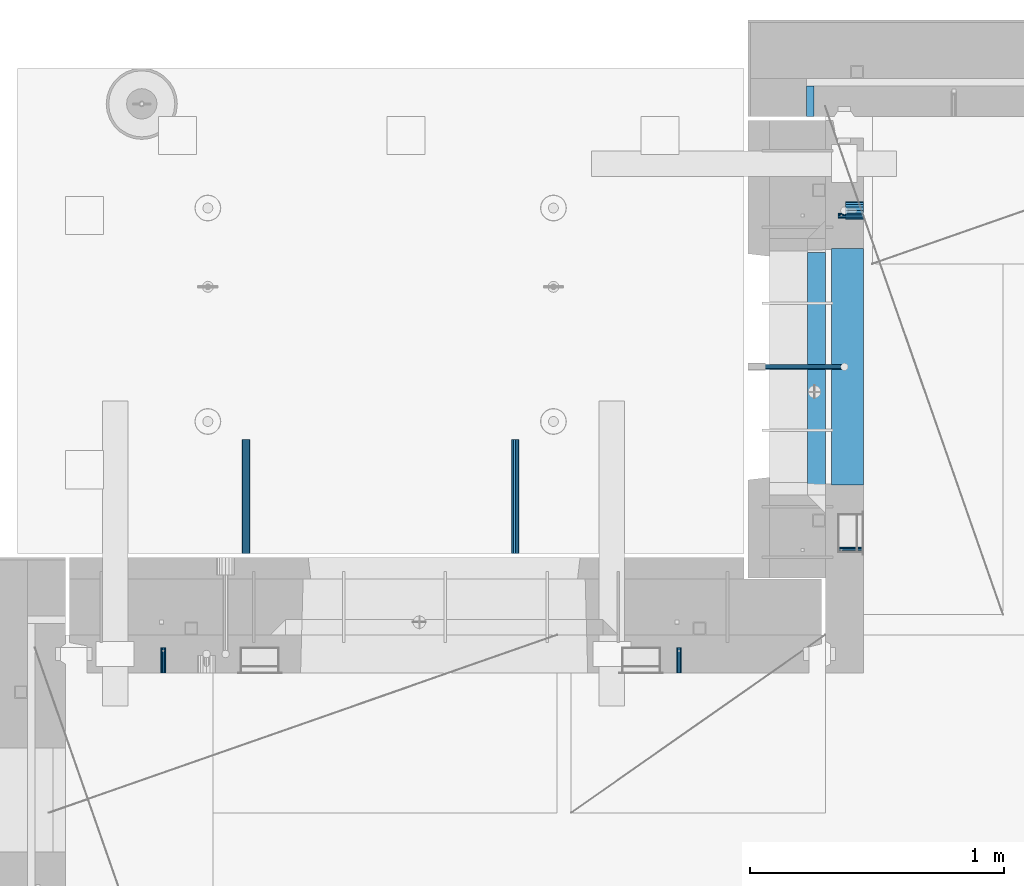
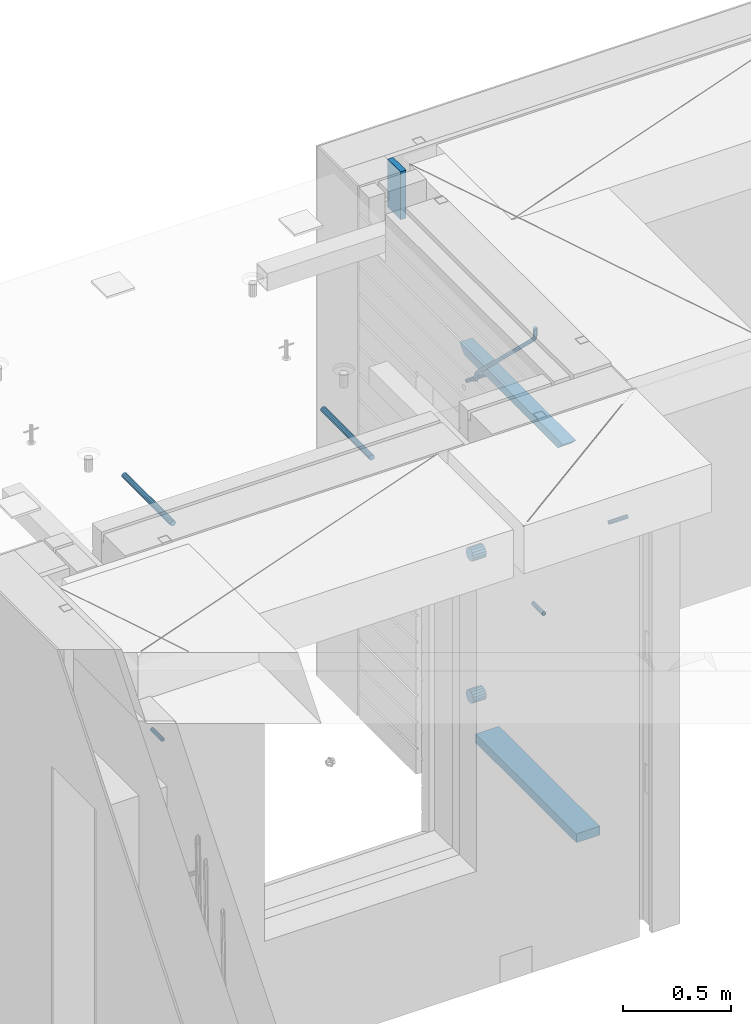
# One storey, part 132 of 309: 12 beams, 10 elements without a shape of their own.
"""IFC2X3 building model written with IfcOpenShell, lengths in millimetres."""

from ifc_helpers import new_model, si_unit, frame, origin_with_axes, place, context, subcontext, project, spatial, faceted_brep, material, type_object, element, aggregate, save


model = new_model("IFC2X3")

# Units and contexts
model_context = context("Model", 3, precision=1e-05, world=origin_with_axes())
body_context = subcontext(model_context, "Body", "Model", "MODEL_VIEW")
ifc_project = project(units=[si_unit("LENGTHUNIT", "METRE", prefix="MILLI"), si_unit("AREAUNIT", "SQUARE_METRE"), si_unit("VOLUMEUNIT", "CUBIC_METRE"), si_unit("MASSUNIT", "GRAM", prefix="KILO"), si_unit("TIMEUNIT", "SECOND"), si_unit("PLANEANGLEUNIT", "RADIAN"), si_unit("SOLIDANGLEUNIT", "STERADIAN"), si_unit("THERMODYNAMICTEMPERATUREUNIT", "DEGREE_CELSIUS"), si_unit("LUMINOUSINTENSITYUNIT", "LUMEN")], contexts=[model_context])

# Site, building, storey
site_placement = place(None, origin_with_axes())
site = spatial("IfcSite", under=ifc_project, at=site_placement, CompositionType="ELEMENT")
building_placement = place(site_placement, origin_with_axes())
building = spatial("IfcBuilding", under=site, at=building_placement, CompositionType="ELEMENT")
storey_placement = place(building_placement, origin_with_axes())
storey = spatial("IfcBuildingStorey", under=building, at=storey_placement, Name="7", CompositionType="ELEMENT", Elevation=0.0)

# Assembly, beam
assembly_1_placement = place(storey_placement, origin_with_axes())
assembly_1 = element("IfcElementAssembly", 1, at=assembly_1_placement, inside=storey, AssemblyPlace="NOTDEFINED", PredefinedType="REINFORCEMENT_UNIT")
ifc_material_1 = material(Name="CONCRETE/C25/30")
beam_type_1 = type_object("IfcBeamType", PredefinedType="NOTDEFINED")
beam_1_placement = place(assembly_1_placement, frame((10955.0, 22139.9998901814, 102080.0), z_axis=(0.0, 0.0, -1.0), x_axis=(0.0, -1.0, 0.0)))
beam_1 = element("IfcBeam", 2, at=beam_1_placement, type_object=beam_type_1, material=ifc_material_1, Name="SK", context=body_context, shape_type="Brep", body=[
    faceted_brep([(100.641025641038, 35.0, 20.6410256410309), (55.0, 35.0, -25.0), (55.0, -35.0, -25.0), (98.8461538461561, -35.0, 18.8461538461561), (966.153464684117, -35.0, 18.8461538461561), (964.358592889246, 35.0, 20.6410256410309), (1009.99961853027, 35.0, -25.0), (1009.99961853027, -35.0, -25.0)], [[[0, 1, 2, 3]], [[0, 3, 4, 5]], [[1, 0, 5, 6]], [[2, 1, 6, 7]], [[3, 2, 7, 4]], [[4, 7, 6, 5]]]),
])

# Assemblies, beams
assembly_2_placement = place(storey_placement, origin_with_axes())
assembly_2 = element("IfcElementAssembly", 3, at=assembly_2_placement, inside=storey, AssemblyPlace="NOTDEFINED", PredefinedType="REINFORCEMENT_UNIT")
assembly_3_placement = place(assembly_2_placement, origin_with_axes())
assembly_3 = element("IfcElementAssembly", 4, at=assembly_3_placement, Name="Steel Assembly", AssemblyPlace="NOTDEFINED", PredefinedType="RIGID_FRAME")
ifc_material_2 = material(Name="STEEL/Steel_Undefined")
beam_type_2 = type_object("IfcBeamType", PredefinedType="NOTDEFINED")
beam_2_placement = place(assembly_3_placement, frame((8384.50481277243, 20430.0, 101754.84), z_axis=(-1.0, 3.00000001838171e-08, 0.0), x_axis=(0.0, 1.0, 0.0)))
beam_2 = element("IfcBeam", 5, at=beam_2_placement, type_object=beam_type_2, material=ifc_material_2, context=body_context, shape_type="Brep", body=[
    faceted_brep([(0.0, -8.49999999999272, -1.45519152283669e-11), (0.0, -7.36121593215648, 4.24999999998545), (100.000000000262, -7.36121593215648, 4.24999999998545), (100.000000000262, -8.49999999999272, -1.45519152283669e-11), (0.0, -4.24999999998545, 7.36121593216376), (100.000000000262, -4.24999999998545, 7.36121593216376), (0.0, 1.45519152283669e-11, 8.49999999998545), (100.000000000262, 1.45519152283669e-11, 8.49999999998545), (0.0, 4.25000000001455, 7.36121593216376), (100.000000000262, 4.25000000001455, 7.36121593216376), (0.0, 7.36121593217104, 4.24999999998545), (100.000000000262, 7.36121593217104, 4.24999999998545), (0.0, 8.50000000000728, 0.0), (100.000000000262, 8.50000000000728, 0.0), (0.0, 7.36121593217104, -4.25000000001455), (100.000000000262, 7.36121593217104, -4.25000000001455), (0.0, 4.25000000000728, -7.36121593219286), (100.000000000262, 4.25000000000728, -7.36121593219286), (0.0, 7.27595761418343e-12, -8.5), (100.000000000262, 7.27595761418343e-12, -8.5), (0.0, -4.24999999999272, -7.36121593217831), (100.000000000262, -4.24999999999272, -7.36121593217831), (0.0, -7.36121593215648, -4.25), (100.000000000262, -7.36121593215648, -4.25), (0.0, -10.4999999999927, -1.45519152283669e-11), (0.0, -9.09326673972828, -5.25000000001455), (100.000000000262, -9.09326673972828, -5.25000000001455), (100.000000000262, -10.4999999999927, -1.45519152283669e-11), (0.0, -5.24999999998545, -9.09326673974283), (100.000000000262, -5.24999999998545, -9.09326673974283), (0.0, 7.27595761418343e-12, -10.5), (100.000000000262, 7.27595761418343e-12, -10.5), (0.0, 5.25000000001455, -9.09326673975738), (100.000000000262, 5.25000000001455, -9.09326673975738), (0.0, 9.09326673975011, -5.25000000001455), (100.000000000262, 9.09326673975011, -5.25000000001455), (0.0, 10.5000000000073, -1.45519152283669e-11), (100.000000000262, 10.5000000000073, -1.45519152283669e-11), (0.0, 9.09326673975011, 5.25), (100.000000000262, 9.09326673975011, 5.25), (0.0, 5.25000000000728, 9.09326673972828), (100.000000000262, 5.25000000000728, 9.09326673972828), (0.0, 1.45519152283669e-11, 10.4999999999854), (100.000000000262, 1.45519152283669e-11, 10.4999999999854), (0.0, -5.24999999999272, 9.09326673972828), (100.000000000262, -5.24999999999272, 9.09326673972828), (0.0, -9.09326673972828, 5.24999999998545), (100.000000000262, -9.09326673972828, 5.24999999998545)], [[[0, 1, 2, 3]], [[1, 4, 5, 2]], [[4, 6, 7, 5]], [[6, 8, 9, 7]], [[8, 10, 11, 9]], [[10, 12, 13, 11]], [[12, 14, 15, 13]], [[14, 16, 17, 15]], [[16, 18, 19, 17]], [[18, 20, 21, 19]], [[20, 22, 23, 21]], [[22, 0, 3, 23]], [[24, 25, 26, 27]], [[25, 28, 29, 26]], [[28, 30, 31, 29]], [[30, 32, 33, 31]], [[32, 34, 35, 33]], [[34, 36, 37, 35]], [[36, 38, 39, 37]], [[38, 40, 41, 39]], [[40, 42, 43, 41]], [[42, 44, 45, 43]], [[44, 46, 47, 45]], [[46, 24, 27, 47]], [[29, 31, 33, 35, 37, 39, 41, 43, 45, 47, 27, 26], [5, 7, 9, 11, 13, 15, 17, 19, 21, 23, 3, 2]], [[46, 44, 42, 40, 38, 36, 34, 32, 30, 28, 25, 24], [22, 20, 18, 16, 14, 12, 10, 8, 6, 4, 1, 0]]]),
])
aggregate(assembly_3, [beam_2])
assembly_4_placement = place(assembly_2_placement, origin_with_axes())
assembly_4 = element("IfcElementAssembly", 6, at=assembly_4_placement, Name="Steel Assembly", AssemblyPlace="NOTDEFINED", PredefinedType="RIGID_FRAME")
aggregate(assembly_2, [assembly_3, assembly_4])
beam_3_placement = place(assembly_4_placement, frame((10414.5048127724, 20430.0, 101754.84), z_axis=(-1.0, 3.00000001838171e-08, 0.0), x_axis=(0.0, 1.0, 0.0)))
beam_3 = element("IfcBeam", 7, at=beam_3_placement, type_object=beam_type_2, material=ifc_material_2, context=body_context, shape_type="Brep", body=[
    faceted_brep([(0.0, -8.49999999999272, -1.45519152283669e-11), (0.0, -7.36121593215648, 4.24999999998545), (100.000000000262, -7.36121593215648, 4.24999999998545), (100.000000000262, -8.49999999999272, -1.45519152283669e-11), (0.0, -4.24999999998545, 7.36121593216376), (100.000000000262, -4.24999999998545, 7.36121593216376), (0.0, 1.45519152283669e-11, 8.49999999998545), (100.000000000262, 1.45519152283669e-11, 8.49999999998545), (0.0, 4.25000000001455, 7.36121593216376), (100.000000000262, 4.25000000001455, 7.36121593216376), (0.0, 7.36121593217104, 4.24999999998545), (100.000000000262, 7.36121593217104, 4.24999999998545), (0.0, 8.50000000000728, 0.0), (100.000000000262, 8.50000000000728, 0.0), (0.0, 7.36121593217104, -4.25000000001455), (100.000000000262, 7.36121593217104, -4.25000000001455), (0.0, 4.25000000000728, -7.36121593219286), (100.000000000262, 4.25000000000728, -7.36121593219286), (0.0, 7.27595761418343e-12, -8.5), (100.000000000262, 7.27595761418343e-12, -8.5), (0.0, -4.24999999999272, -7.36121593217831), (100.000000000262, -4.24999999999272, -7.36121593217831), (0.0, -7.36121593215648, -4.25), (100.000000000262, -7.36121593215648, -4.25), (0.0, -10.4999999999927, -1.45519152283669e-11), (0.0, -9.09326673972828, -5.25000000001455), (100.000000000262, -9.09326673972828, -5.25000000001455), (100.000000000262, -10.4999999999927, -1.45519152283669e-11), (0.0, -5.24999999998545, -9.09326673974283), (100.000000000262, -5.24999999998545, -9.09326673974283), (0.0, 7.27595761418343e-12, -10.5), (100.000000000262, 7.27595761418343e-12, -10.5), (0.0, 5.25000000001455, -9.09326673975738), (100.000000000262, 5.25000000001455, -9.09326673975738), (0.0, 9.09326673975011, -5.25000000001455), (100.000000000262, 9.09326673975011, -5.25000000001455), (0.0, 10.5000000000073, -1.45519152283669e-11), (100.000000000262, 10.5000000000073, -1.45519152283669e-11), (0.0, 9.09326673975011, 5.25), (100.000000000262, 9.09326673975011, 5.25), (0.0, 5.25000000000728, 9.09326673972828), (100.000000000262, 5.25000000000728, 9.09326673972828), (0.0, 1.45519152283669e-11, 10.4999999999854), (100.000000000262, 1.45519152283669e-11, 10.4999999999854), (0.0, -5.24999999999272, 9.09326673972828), (100.000000000262, -5.24999999999272, 9.09326673972828), (0.0, -9.09326673972828, 5.24999999998545), (100.000000000262, -9.09326673972828, 5.24999999998545)], [[[0, 1, 2, 3]], [[1, 4, 5, 2]], [[4, 6, 7, 5]], [[6, 8, 9, 7]], [[8, 10, 11, 9]], [[10, 12, 13, 11]], [[12, 14, 15, 13]], [[14, 16, 17, 15]], [[16, 18, 19, 17]], [[18, 20, 21, 19]], [[20, 22, 23, 21]], [[22, 0, 3, 23]], [[24, 25, 26, 27]], [[25, 28, 29, 26]], [[28, 30, 31, 29]], [[30, 32, 33, 31]], [[32, 34, 35, 33]], [[34, 36, 37, 35]], [[36, 38, 39, 37]], [[38, 40, 41, 39]], [[40, 42, 43, 41]], [[42, 44, 45, 43]], [[44, 46, 47, 45]], [[46, 24, 27, 47]], [[29, 31, 33, 35, 37, 39, 41, 43, 45, 47, 27, 26], [5, 7, 9, 11, 13, 15, 17, 19, 21, 23, 3, 2]], [[46, 44, 42, 40, 38, 36, 34, 32, 30, 28, 25, 24], [22, 20, 18, 16, 14, 12, 10, 8, 6, 4, 1, 0]]]),
])
aggregate(assembly_4, [beam_3])

# Assembly, beam
assembly_5_placement = place(assembly_1_placement, origin_with_axes())
assembly_5 = element("IfcElementAssembly", 8, at=assembly_5_placement, Name="Steel Assembly", AssemblyPlace="NOTDEFINED", PredefinedType="RIGID_FRAME")
beam_4_placement = place(assembly_5_placement, frame((11140.0, 22230.0002037383, 101755.0), z_axis=(0.0, 1.0, 0.0), x_axis=(-1.0, 3.00000001838171e-08, 0.0)))
beam_4 = element("IfcBeam", 9, at=beam_4_placement, type_object=beam_type_2, material=ifc_material_2, Name="M16", context=body_context, shape_type="Brep", body=[
    faceted_brep([(0.0, -8.49999999999272, -1.45519152283669e-11), (0.0, -7.36121593215648, 4.24999999998545), (100.000000000262, -7.36121593215648, 4.24999999998545), (100.000000000262, -8.49999999999272, -1.45519152283669e-11), (0.0, -4.24999999998545, 7.36121593216376), (100.000000000262, -4.24999999998545, 7.36121593216376), (0.0, 1.45519152283669e-11, 8.49999999998545), (100.000000000262, 1.45519152283669e-11, 8.49999999998545), (0.0, 4.25000000001455, 7.36121593216376), (100.000000000262, 4.25000000001455, 7.36121593216376), (0.0, 7.36121593217104, 4.24999999998545), (100.000000000262, 7.36121593217104, 4.24999999998545), (0.0, 8.50000000000728, 0.0), (100.000000000262, 8.50000000000728, 0.0), (0.0, 7.36121593217104, -4.25000000001455), (100.000000000262, 7.36121593217104, -4.25000000001455), (0.0, 4.25000000000728, -7.36121593219286), (100.000000000262, 4.25000000000728, -7.36121593219286), (0.0, 7.27595761418343e-12, -8.5), (100.000000000262, 7.27595761418343e-12, -8.5), (0.0, -4.24999999999272, -7.36121593217831), (100.000000000262, -4.24999999999272, -7.36121593217831), (0.0, -7.36121593215648, -4.25), (100.000000000262, -7.36121593215648, -4.25), (0.0, -10.4999999999927, -1.45519152283669e-11), (0.0, -9.09326673972828, -5.25000000001455), (100.000000000262, -9.09326673972828, -5.25000000001455), (100.000000000262, -10.4999999999927, -1.45519152283669e-11), (0.0, -5.24999999998545, -9.09326673974283), (100.000000000262, -5.24999999998545, -9.09326673974283), (0.0, 7.27595761418343e-12, -10.5), (100.000000000262, 7.27595761418343e-12, -10.5), (0.0, 5.25000000001455, -9.09326673975738), (100.000000000262, 5.25000000001455, -9.09326673975738), (0.0, 9.09326673975011, -5.25000000001455), (100.000000000262, 9.09326673975011, -5.25000000001455), (0.0, 10.5000000000073, -1.45519152283669e-11), (100.000000000262, 10.5000000000073, -1.45519152283669e-11), (0.0, 9.09326673975011, 5.25), (100.000000000262, 9.09326673975011, 5.25), (0.0, 5.25000000000728, 9.09326673972828), (100.000000000262, 5.25000000000728, 9.09326673972828), (0.0, 1.45519152283669e-11, 10.4999999999854), (100.000000000262, 1.45519152283669e-11, 10.4999999999854), (0.0, -5.24999999999272, 9.09326673972828), (100.000000000262, -5.24999999999272, 9.09326673972828), (0.0, -9.09326673972828, 5.24999999998545), (100.000000000262, -9.09326673972828, 5.24999999998545)], [[[0, 1, 2, 3]], [[1, 4, 5, 2]], [[4, 6, 7, 5]], [[6, 8, 9, 7]], [[8, 10, 11, 9]], [[10, 12, 13, 11]], [[12, 14, 15, 13]], [[14, 16, 17, 15]], [[16, 18, 19, 17]], [[18, 20, 21, 19]], [[20, 22, 23, 21]], [[22, 0, 3, 23]], [[24, 25, 26, 27]], [[25, 28, 29, 26]], [[28, 30, 31, 29]], [[30, 32, 33, 31]], [[32, 34, 35, 33]], [[34, 36, 37, 35]], [[36, 38, 39, 37]], [[38, 40, 41, 39]], [[40, 42, 43, 41]], [[42, 44, 45, 43]], [[44, 46, 47, 45]], [[46, 24, 27, 47]], [[29, 31, 33, 35, 37, 39, 41, 43, 45, 47, 27, 26], [5, 7, 9, 11, 13, 15, 17, 19, 21, 23, 3, 2]], [[46, 44, 42, 40, 38, 36, 34, 32, 30, 28, 25, 24], [22, 20, 18, 16, 14, 12, 10, 8, 6, 4, 1, 0]]]),
])
aggregate(assembly_5, [beam_4])

assembly_6_placement = place(assembly_1_placement, origin_with_axes())
assembly_6 = element("IfcElementAssembly", 10, at=assembly_6_placement, Name="Steel Assembly", AssemblyPlace="NOTDEFINED", PredefinedType="RIGID_FRAME")
beam_5_placement = place(assembly_6_placement, frame((11140.0, 20914.9954408996, 101755.0), z_axis=(0.0, -1.0, 0.0), x_axis=(-1.0, 3.00000001838171e-08, 0.0)))
beam_5 = element("IfcBeam", 11, at=beam_5_placement, type_object=beam_type_2, material=ifc_material_2, Name="M16", context=body_context, shape_type="Brep", body=[
    faceted_brep([(0.0, -8.49999999999272, -1.45519152283669e-11), (0.0, -7.36121593215648, 4.24999999998545), (100.000000000262, -7.36121593215648, 4.24999999998545), (100.000000000262, -8.49999999999272, -1.45519152283669e-11), (0.0, -4.24999999998545, 7.36121593216376), (100.000000000262, -4.24999999998545, 7.36121593216376), (0.0, 1.45519152283669e-11, 8.49999999998545), (100.000000000262, 1.45519152283669e-11, 8.49999999998545), (0.0, 4.25000000001455, 7.36121593216376), (100.000000000262, 4.25000000001455, 7.36121593216376), (0.0, 7.36121593217104, 4.24999999998545), (100.000000000262, 7.36121593217104, 4.24999999998545), (0.0, 8.50000000000728, 0.0), (100.000000000262, 8.50000000000728, 0.0), (0.0, 7.36121593217104, -4.25000000001455), (100.000000000262, 7.36121593217104, -4.25000000001455), (0.0, 4.25000000000728, -7.36121593219286), (100.000000000262, 4.25000000000728, -7.36121593219286), (0.0, 7.27595761418343e-12, -8.5), (100.000000000262, 7.27595761418343e-12, -8.5), (0.0, -4.24999999999272, -7.36121593217831), (100.000000000262, -4.24999999999272, -7.36121593217831), (0.0, -7.36121593215648, -4.25), (100.000000000262, -7.36121593215648, -4.25), (0.0, -10.4999999999927, -1.45519152283669e-11), (0.0, -9.09326673972828, -5.25000000001455), (100.000000000262, -9.09326673972828, -5.25000000001455), (100.000000000262, -10.4999999999927, -1.45519152283669e-11), (0.0, -5.24999999998545, -9.09326673974283), (100.000000000262, -5.24999999998545, -9.09326673974283), (0.0, 7.27595761418343e-12, -10.5), (100.000000000262, 7.27595761418343e-12, -10.5), (0.0, 5.25000000001455, -9.09326673975738), (100.000000000262, 5.25000000001455, -9.09326673975738), (0.0, 9.09326673975011, -5.25000000001455), (100.000000000262, 9.09326673975011, -5.25000000001455), (0.0, 10.5000000000073, -1.45519152283669e-11), (100.000000000262, 10.5000000000073, -1.45519152283669e-11), (0.0, 9.09326673975011, 5.25), (100.000000000262, 9.09326673975011, 5.25), (0.0, 5.25000000000728, 9.09326673972828), (100.000000000262, 5.25000000000728, 9.09326673972828), (0.0, 1.45519152283669e-11, 10.4999999999854), (100.000000000262, 1.45519152283669e-11, 10.4999999999854), (0.0, -5.24999999999272, 9.09326673972828), (100.000000000262, -5.24999999999272, 9.09326673972828), (0.0, -9.09326673972828, 5.24999999998545), (100.000000000262, -9.09326673972828, 5.24999999998545)], [[[0, 1, 2, 3]], [[1, 4, 5, 2]], [[4, 6, 7, 5]], [[6, 8, 9, 7]], [[8, 10, 11, 9]], [[10, 12, 13, 11]], [[12, 14, 15, 13]], [[14, 16, 17, 15]], [[16, 18, 19, 17]], [[18, 20, 21, 19]], [[20, 22, 23, 21]], [[22, 0, 3, 23]], [[24, 25, 26, 27]], [[25, 28, 29, 26]], [[28, 30, 31, 29]], [[30, 32, 33, 31]], [[32, 34, 35, 33]], [[34, 36, 37, 35]], [[36, 38, 39, 37]], [[38, 40, 41, 39]], [[40, 42, 43, 41]], [[42, 44, 45, 43]], [[44, 46, 47, 45]], [[46, 24, 27, 47]], [[29, 31, 33, 35, 37, 39, 41, 43, 45, 47, 27, 26], [5, 7, 9, 11, 13, 15, 17, 19, 21, 23, 3, 2]], [[46, 44, 42, 40, 38, 36, 34, 32, 30, 28, 25, 24], [22, 20, 18, 16, 14, 12, 10, 8, 6, 4, 1, 0]]]),
])
aggregate(assembly_6, [beam_5])

# Beam
ifc_material_3 = material()
beam_type_3 = type_object("IfcBeamType", Name="D20", PredefinedType="NOTDEFINED")
beam_6_placement = place(assembly_1_placement, frame((10747.93, 21634.9982799665, 102220.28), z_axis=(0.999209485784166, 0.00020572799995638, -0.0397537569914116), x_axis=(0.0397537569984931, -6.39999925638531e-08, 0.999209506962629)))
beam_6 = element("IfcBeam", 12, at=beam_6_placement, type_object=beam_type_3, material=ifc_material_3, Name="JM20", ObjectType="D20", context=body_context, shape_type="Brep", body=[
    faceted_brep([(0.0, -10.0, 0.0), (-4.19531716033816e-08, -7.07106781186667, -7.07106781187031), (26.3851730625611, -7.07106780271351, -7.07106779974674), (26.3851730660535, -9.99999999077045, 1.18243406177498e-08), (0.0, 0.0, -10.0), (26.3851730589668, 9.14587872102857e-09, -9.99999998788189), (4.196772351861e-08, 7.07106781186303, -7.07106781186667), (26.3851730576571, 7.07106782101255, -7.0710677997472), (0.0, 10.0, 0.0), (26.3851730593888, 10.0000000091495, 1.21176526590716e-08), (4.196772351861e-08, 7.07106781185939, 7.07106781185939), (26.3851730631723, 7.07106782101619, 7.07106782398387), (0.0, 0.0, 10.0), (26.3851730667375, 9.15315467864275e-09, 10.0000000121181), (-4.19531716033816e-08, -7.07106781187031, 7.07106781185939), (26.3851730680617, -7.07106780271351, 7.07106782398296), (38.6387990555377, 0.00053833780111745, -7.38336449283906), (37.4430586178205, -7.07058200552274, -4.70977034770021), (34.5550974405633, -9.99964106806146, 1.74460312923975), (31.6666440137633, -7.07083577596131, 8.19887149183023), (30.4697151806322, 0.000179452214069897, 10.8722118684241), (31.6654556183639, 7.07129979554884, 8.19861772327886), (34.5534167956066, 10.0003588580803, 1.74424424634026), (37.4418702223775, 7.07155356597286, -4.71002411625204), (46.5698109210789, 7.07292605872499, 1.96124086770624), (48.7548734831362, 0.00205940803425619, 0.0100898832683924), (41.2967727296491, 10.0013728005906, 6.67270684289633), (36.0246331664675, 7.07195524891722, 11.3845749391899), (33.8417400848848, 0.000686475628754124, 13.3366967298962), (36.0268026468402, -7.07018017507653, 11.385545745416), (41.2998408382991, -9.99862691692761, 6.67407977023777), (46.5719804015243, -7.06920936526149, 1.96221167398289), (52.1766955363273, 7.07494587836845, 11.77897587077), (54.9687243336812, 0.00429788071051007, 10.8906314292522), (45.4389138642146, 10.0028649622, 13.9256551011317), (38.7022804405424, 7.07291984242329, 16.0731735411446), (35.9130237601494, 0.00143263318750542, 16.9635440140905), (38.7050525575032, -7.06921536447044, 16.0751995724927), (45.4428342298197, -9.99713444846202, 13.9285203429881), (52.1794676532882, -7.06718932852891, 11.7810019021831), (142.166420299589, -7.00909836739083, 294.143799597011), (135.429786872017, -9.93904348683645, 296.291318034092), (144.955676979953, 0.0623888418631395, 293.253429124143), (142.163648182657, 7.13303683951744, 294.141773565681), (135.425866510661, 10.0609559233271, 296.288452795829), (128.689233087061, 7.13101080351771, 298.435971235634), (125.899976406712, 0.0595235942673753, 299.326341708503), (128.692005203993, -7.01112440339057, 298.437997266966), (147.068569920637, 0.0631443010061048, 296.926548661886), (144.897857494318, -7.00812174957537, 298.892215917644), (139.655137467547, -9.93753272500544, 303.636800386314), (134.411524128242, -7.00907940566321, 308.380988833921), (132.238655054738, 0.0617899707685865, 310.345700010335), (134.409367481101, 7.13305602133914, 308.38003275464), (139.652087507944, 10.0624669967765, 303.63544828606), (144.895700847192, 7.13401367743427, 298.891259838389), (149.349355837621, 7.13466950711154, 302.082919188319), (150.512901837996, 0.0636515012993186, 299.394888529177), (146.541460642286, 10.0634815017911, 308.572636332), (143.734043175544, 7.13442914049301, 315.062451673432), (142.571650514263, 0.0633115715718304, 317.750719402909), (143.735196514695, -7.0077064342513, 315.062688743805), (146.543091710148, -9.93651842893087, 308.572971600169), (149.350509176773, -7.0074660676255, 302.083156258706), (154.724909358454, 7.13488656737172, 303.143653317829), (154.670204234542, 0.063819369621342, 300.215230568659), (154.856921558763, 10.0638172729959, 310.213489346082), (154.988909878753, 7.13488360238989, 317.283324591871), (155.043557350815, 0.0638151764978829, 320.211745451903), (154.988852227005, -7.00725202125614, 317.28332270274), (154.856840031658, -9.93618272723688, 310.213486674455), (154.724851706691, -7.00724905626703, 303.143651428684), (199.544700311235, -7.00743165723543, 302.30682413155), (199.676688632229, -9.93636532781238, 309.37665937721), (199.490052838737, 0.0636367686238373, 299.378403271518), (199.544757962984, 7.13470396637786, 302.306826020583), (199.676770164122, 10.0636346720203, 309.376662048705), (199.808758485131, 7.13470100144696, 316.446497294365), (199.863405957614, 0.0636325755804137, 319.374918154397), (199.808700833368, -7.00743462216269, 316.446495405334)], [[[0, 1, 2, 3]], [[1, 4, 5, 2]], [[4, 6, 7, 5]], [[6, 8, 9, 7]], [[8, 10, 11, 9]], [[10, 12, 13, 11]], [[12, 14, 15, 13]], [[14, 0, 3, 15]], [[14, 12, 10, 8, 6, 4, 1, 0]], [[2, 5, 16, 17]], [[3, 2, 17, 18]], [[15, 3, 18, 19]], [[13, 15, 19, 20]], [[11, 13, 20, 21]], [[9, 11, 21, 22]], [[7, 9, 22, 23]], [[5, 7, 23, 16]], [[23, 24, 25, 16]], [[22, 26, 24, 23]], [[21, 27, 26, 22]], [[20, 28, 27, 21]], [[19, 29, 28, 20]], [[18, 30, 29, 19]], [[17, 31, 30, 18]], [[16, 25, 31, 17]], [[24, 32, 33, 25]], [[26, 34, 32, 24]], [[27, 35, 34, 26]], [[28, 36, 35, 27]], [[29, 37, 36, 28]], [[30, 38, 37, 29]], [[31, 39, 38, 30]], [[25, 33, 39, 31]], [[38, 39, 40, 41]], [[39, 33, 42, 40]], [[33, 32, 43, 42]], [[32, 34, 44, 43]], [[34, 35, 45, 44]], [[35, 36, 46, 45]], [[36, 37, 47, 46]], [[37, 38, 41, 47]], [[40, 42, 48, 49]], [[41, 40, 49, 50]], [[47, 41, 50, 51]], [[46, 47, 51, 52]], [[45, 46, 52, 53]], [[44, 45, 53, 54]], [[43, 44, 54, 55]], [[42, 43, 55, 48]], [[55, 56, 57, 48]], [[54, 58, 56, 55]], [[53, 59, 58, 54]], [[52, 60, 59, 53]], [[51, 61, 60, 52]], [[50, 62, 61, 51]], [[49, 63, 62, 50]], [[48, 57, 63, 49]], [[56, 64, 65, 57]], [[58, 66, 64, 56]], [[59, 67, 66, 58]], [[60, 68, 67, 59]], [[61, 69, 68, 60]], [[62, 70, 69, 61]], [[63, 71, 70, 62]], [[57, 65, 71, 63]], [[70, 71, 72, 73]], [[71, 65, 74, 72]], [[65, 64, 75, 74]], [[64, 66, 76, 75]], [[66, 67, 77, 76]], [[67, 68, 78, 77]], [[68, 69, 79, 78]], [[69, 70, 73, 79]], [[74, 75, 76, 77, 78, 79, 73, 72]]]),
])

beam_type_4 = type_object("IfcBeamType", Name="D70", PredefinedType="NOTDEFINED")
beam_7_placement = place(assembly_1_placement, frame((11140.0, 22250.0036667336, 100755.0), z_axis=(0.0, 0.0, 1.0), x_axis=(-1.0, 3.00000001838171e-08, 0.0)))
beam_7 = element("IfcBeam", 13, at=beam_7_placement, type_object=beam_type_4, material=ifc_material_3, ObjectType="D70", context=body_context, shape_type="Brep", body=[
    faceted_brep([(0.0, -35.0, 0.0), (0.0, -32.3357836378964, -13.3939201327739), (70.0, -32.3357836378964, -13.3939201327739), (70.0, -35.0, 0.0), (0.0, -24.7487373415279, -24.7487373415352), (70.0, -24.7487373415279, -24.7487373415352), (0.0, -13.3939201327776, -32.3357836379), (70.0, -13.3939201327776, -32.3357836379), (0.0, 0.0, -35.0), (70.0, 0.0, -35.0), (0.0, 13.3939201327776, -32.3357836379), (70.0, 13.3939201327776, -32.3357836379), (0.0, 24.7487373415279, -24.7487373415352), (70.0, 24.7487373415279, -24.7487373415352), (0.0, 32.3357836378964, -13.3939201327739), (70.0, 32.3357836378964, -13.3939201327739), (0.0, 35.0, 0.0), (70.0, 35.0, 0.0), (0.0, 32.3357836378964, 13.3939201327739), (70.0, 32.3357836378964, 13.3939201327739), (0.0, 24.7487373415279, 24.7487373415352), (70.0, 24.7487373415279, 24.7487373415352), (0.0, 13.3939201327776, 32.3357836379), (70.0, 13.3939201327776, 32.3357836379), (0.0, 0.0, 35.0), (70.0, 0.0, 35.0), (0.0, -13.3939201327776, 32.3357836379), (70.0, -13.3939201327776, 32.3357836379), (0.0, -24.7487373415279, 24.7487373415352), (70.0, -24.7487373415279, 24.7487373415352), (0.0, -32.3357836378964, 13.3939201327739), (70.0, -32.3357836378964, 13.3939201327739)], [[[0, 1, 2, 3]], [[1, 4, 5, 2]], [[4, 6, 7, 5]], [[6, 8, 9, 7]], [[8, 10, 11, 9]], [[10, 12, 13, 11]], [[12, 14, 15, 13]], [[14, 16, 17, 15]], [[16, 18, 19, 17]], [[18, 20, 21, 19]], [[20, 22, 23, 21]], [[22, 24, 25, 23]], [[24, 26, 27, 25]], [[26, 28, 29, 27]], [[28, 30, 31, 29]], [[30, 0, 3, 31]], [[5, 7, 9, 11, 13, 15, 17, 19, 21, 23, 25, 27, 29, 31, 3, 2]], [[30, 28, 26, 24, 22, 20, 18, 16, 14, 12, 10, 8, 6, 4, 1, 0]]]),
])

beam_8_placement = place(assembly_1_placement, frame((11140.0, 22250.003666727, 99955.0), z_axis=(0.0, 0.0, 1.0), x_axis=(-1.0, 3.00000001838171e-08, 0.0)))
beam_8 = element("IfcBeam", 14, at=beam_8_placement, type_object=beam_type_4, material=ifc_material_3, ObjectType="D70", context=body_context, shape_type="Brep", body=[
    faceted_brep([(0.0, -35.0, 0.0), (0.0, -32.3357836378964, -13.3939201327739), (70.0, -32.3357836378964, -13.3939201327739), (70.0, -35.0, 0.0), (0.0, -24.7487373415279, -24.7487373415352), (70.0, -24.7487373415279, -24.7487373415352), (0.0, -13.3939201327776, -32.3357836379), (70.0, -13.3939201327776, -32.3357836379), (0.0, 0.0, -35.0), (70.0, 0.0, -35.0), (0.0, 13.3939201327776, -32.3357836379), (70.0, 13.3939201327776, -32.3357836379), (0.0, 24.7487373415279, -24.7487373415352), (70.0, 24.7487373415279, -24.7487373415352), (0.0, 32.3357836378964, -13.3939201327739), (70.0, 32.3357836378964, -13.3939201327739), (0.0, 35.0, 0.0), (70.0, 35.0, 0.0), (0.0, 32.3357836378964, 13.3939201327739), (70.0, 32.3357836378964, 13.3939201327739), (0.0, 24.7487373415279, 24.7487373415352), (70.0, 24.7487373415279, 24.7487373415352), (0.0, 13.3939201327776, 32.3357836379), (70.0, 13.3939201327776, 32.3357836379), (0.0, 0.0, 35.0), (70.0, 0.0, 35.0), (0.0, -13.3939201327776, 32.3357836379), (70.0, -13.3939201327776, 32.3357836379), (0.0, -24.7487373415279, 24.7487373415352), (70.0, -24.7487373415279, 24.7487373415352), (0.0, -32.3357836378964, 13.3939201327739), (70.0, -32.3357836378964, 13.3939201327739)], [[[0, 1, 2, 3]], [[1, 4, 5, 2]], [[4, 6, 7, 5]], [[6, 8, 9, 7]], [[8, 10, 11, 9]], [[10, 12, 13, 11]], [[12, 14, 15, 13]], [[14, 16, 17, 15]], [[16, 18, 19, 17]], [[18, 20, 21, 19]], [[20, 22, 23, 21]], [[22, 24, 25, 23]], [[24, 26, 27, 25]], [[26, 28, 29, 27]], [[28, 30, 31, 29]], [[30, 0, 3, 31]], [[5, 7, 9, 11, 13, 15, 17, 19, 21, 23, 25, 27, 29, 31, 3, 2]], [[30, 28, 26, 24, 22, 20, 18, 16, 14, 12, 10, 8, 6, 4, 1, 0]]]),
])

ifc_material_4 = material(Name="TIMBER/PUU")
beam_type_5 = type_object("IfcBeamType", PredefinedType="NOTDEFINED")
beam_9_placement = place(assembly_1_placement, frame((11077.5, 21169.9999618525, 99830.0), z_axis=(0.0, 0.0, 1.0), x_axis=(0.0, 1.0, 0.0)))
beam_9 = element("IfcBeam", 15, at=beam_9_placement, type_object=beam_type_5, material=ifc_material_4, context=body_context, shape_type="Brep", body=[
    faceted_brep([(0.0, 62.5, -25.0), (0.0, 62.5, 25.0), (930.0, 62.5, 25.0), (930.0, 62.5, -25.0), (0.0, -62.5, 25.0), (930.0, -62.5, 25.0), (0.0, -62.5, -25.0), (930.0, -62.5, -25.0)], [[[0, 1, 2, 3]], [[1, 4, 5, 2]], [[4, 6, 7, 5]], [[6, 0, 3, 7]], [[5, 7, 3, 2]], [[6, 4, 1, 0]]]),
])

aggregate(assembly_1, [beam_7, beam_8, beam_6, assembly_5, assembly_6, beam_9, beam_1])

# Assemblies, beams
assembly_7_placement = place(storey_placement, origin_with_axes())
assembly_7 = element("IfcElementAssembly", 16, at=assembly_7_placement, inside=storey, AssemblyPlace="NOTDEFINED", PredefinedType="REINFORCEMENT_UNIT")
assembly_8_placement = place(assembly_7_placement, origin_with_axes())
assembly_8 = element("IfcElementAssembly", 17, at=assembly_8_placement, Name="Steel Assembly", AssemblyPlace="NOTDEFINED", PredefinedType="RIGID_FRAME")
ifc_material_5 = material(Name="STEEL/S235JR")
beam_type_6 = type_object("IfcBeamType", Name="D30", PredefinedType="NOTDEFINED")
beam_10_placement = place(assembly_8_placement, frame((8709.99985675633, 20900.0253394533, 102575.0), z_axis=(0.0, 0.0, 1.0), x_axis=(0.0, 1.0, 0.0)))
beam_10 = element("IfcBeam", 18, at=beam_10_placement, type_object=beam_type_6, material=ifc_material_5, Name="Rd30", ObjectType="D30", context=body_context, shape_type="Brep", body=[
    faceted_brep([(0.0, -15.0, 0.0), (0.0, -12.9903810567666, -7.5), (450.0, -12.9903810567666, -7.5), (450.0, -15.0, 0.0), (0.0, -7.5, -12.9903810567666), (450.0, -7.5, -12.990381056763), (0.0, 0.0, -15.0), (450.0, 0.0, -15.0), (0.0, 7.5, -12.9903810567666), (450.0, 7.5, -12.990381056763), (0.0, 12.9903810567666, -7.5), (450.0, 12.9903810567666, -7.5), (0.0, 15.0, 0.0), (450.0, 15.0, 0.0), (0.0, 12.9903810567666, 7.5), (450.0, 12.9903810567666, 7.5), (0.0, 7.5, 12.9903810567666), (450.0, 7.5, 12.990381056763), (0.0, 0.0, 15.0), (450.0, 0.0, 15.0), (0.0, -7.5, 12.9903810567666), (450.0, -7.5, 12.990381056763), (0.0, -12.9903810567666, 7.5), (450.0, -12.9903810567666, 7.5)], [[[0, 1, 2, 3]], [[1, 4, 5, 2]], [[4, 6, 7, 5]], [[6, 8, 9, 7]], [[8, 10, 11, 9]], [[10, 12, 13, 11]], [[12, 14, 15, 13]], [[14, 16, 17, 15]], [[16, 18, 19, 17]], [[18, 20, 21, 19]], [[20, 22, 23, 21]], [[22, 0, 3, 23]], [[5, 7, 9, 11, 13, 15, 17, 19, 21, 23, 3, 2]], [[22, 20, 18, 16, 14, 12, 10, 8, 6, 4, 1, 0]]]),
])
aggregate(assembly_8, [beam_10])
assembly_9_placement = place(assembly_7_placement, origin_with_axes())
assembly_9 = element("IfcElementAssembly", 19, at=assembly_9_placement, Name="Steel Assembly", AssemblyPlace="NOTDEFINED", PredefinedType="RIGID_FRAME")
aggregate(assembly_7, [assembly_8, assembly_9])
beam_11_placement = place(assembly_9_placement, frame((9769.99985700661, 20900.0152136098, 102575.0), z_axis=(0.0, 0.0, 1.0), x_axis=(0.0, 1.0, 0.0)))
beam_11 = element("IfcBeam", 20, at=beam_11_placement, type_object=beam_type_6, material=ifc_material_5, Name="Rd30", ObjectType="D30", context=body_context, shape_type="Brep", body=[
    faceted_brep([(0.0, -15.0, 0.0), (0.0, -12.9903810567666, -7.5), (450.0, -12.9903810567666, -7.5), (450.0, -15.0, 0.0), (0.0, -7.5, -12.9903810567666), (450.0, -7.5, -12.990381056763), (0.0, 0.0, -15.0), (450.0, 0.0, -15.0), (0.0, 7.5, -12.9903810567666), (450.0, 7.5, -12.990381056763), (0.0, 12.9903810567666, -7.5), (450.0, 12.9903810567666, -7.5), (0.0, 15.0, 0.0), (450.0, 15.0, 0.0), (0.0, 12.9903810567666, 7.5), (450.0, 12.9903810567666, 7.5), (0.0, 7.5, 12.9903810567666), (450.0, 7.5, 12.990381056763), (0.0, 0.0, 15.0), (450.0, 0.0, 15.0), (0.0, -7.5, 12.9903810567666), (450.0, -7.5, 12.990381056763), (0.0, -12.9903810567666, 7.5), (450.0, -12.9903810567666, 7.5)], [[[0, 1, 2, 3]], [[1, 4, 5, 2]], [[4, 6, 7, 5]], [[6, 8, 9, 7]], [[8, 10, 11, 9]], [[10, 12, 13, 11]], [[12, 14, 15, 13]], [[14, 16, 17, 15]], [[16, 18, 19, 17]], [[18, 20, 21, 19]], [[20, 22, 23, 21]], [[22, 0, 3, 23]], [[5, 7, 9, 11, 13, 15, 17, 19, 21, 23, 3, 2]], [[22, 20, 18, 16, 14, 12, 10, 8, 6, 4, 1, 0]]]),
])
aggregate(assembly_9, [beam_11])

# Assembly, beam
assembly_10_placement = place(storey_placement, origin_with_axes())
assembly_10 = element("IfcElementAssembly", 21, at=assembly_10_placement, inside=storey, AssemblyPlace="NOTDEFINED", PredefinedType="REINFORCEMENT_UNIT")
beam_type_7 = type_object("IfcBeamType", Name="270X30", PredefinedType="NOTDEFINED")
beam_12_placement = place(assembly_10_placement, frame((10930.0, 22739.9999999888, 102604.999999997), z_axis=(0.0, 0.0, 1.0), x_axis=(0.0, -1.0, 0.0)))
beam_12 = element("IfcBeam", 22, at=beam_12_placement, type_object=beam_type_7, material=ifc_material_1, ObjectType="270X30", context=body_context, shape_type="Brep", body=[
    faceted_brep([(0.0, 15.0, -135.0), (0.0, 15.0, 135.0), (119.999999999978, 15.0, 135.0), (119.999999999978, 15.0, -135.0), (0.0, -15.0, 135.0), (119.999999999978, -15.0, 135.0), (0.0, -15.0, -135.0), (119.999999999978, -15.0, -135.0)], [[[0, 1, 2, 3]], [[1, 4, 5, 2]], [[4, 6, 7, 5]], [[6, 0, 3, 7]], [[5, 7, 3, 2]], [[6, 4, 1, 0]]]),
])
aggregate(assembly_10, [beam_12])

save(model, "model.ifc")
